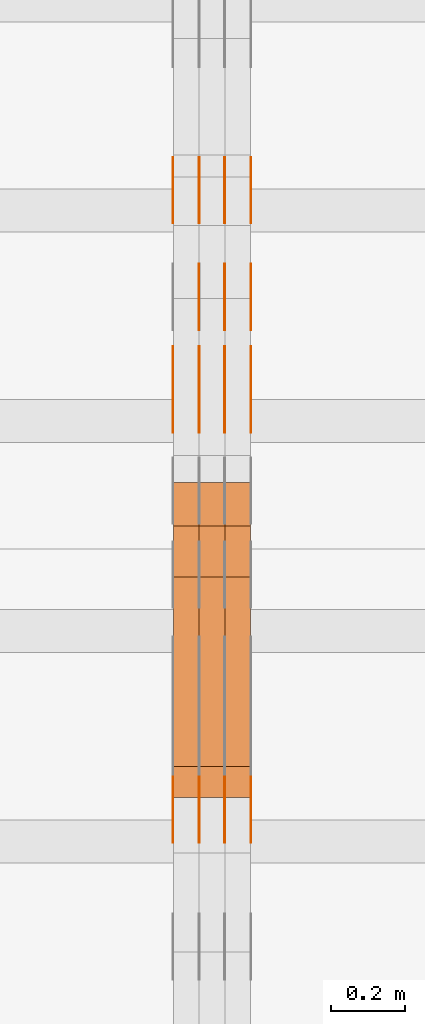
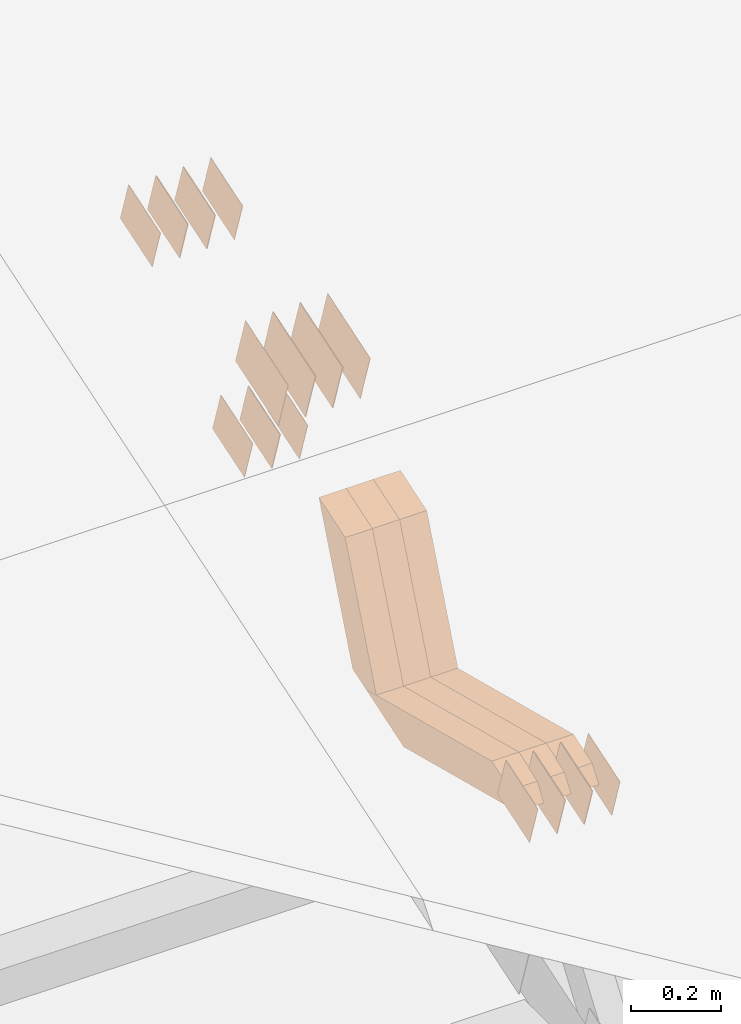
# One storey, part 116 of 385: 28 proxies.
"""IFC2X3 building model written with IfcOpenShell, lengths in millimetres."""

from ifc_helpers import new_model, entity, si_unit, converted_unit, derived_unit, direction, frame, origin, place, context, subcontext, project, spatial, polyline, outline, extrude, source, transform, mapped, material, type_object, type_shapes, element, save


model = new_model("IFC2X3")

# Units and contexts
model_context = context("Model", 3, precision=0.01, world=origin(), true_north=direction((6.12303176911189e-17, 1.0)))
body_context = subcontext(model_context, "Body", "Model", "MODEL_VIEW")
ifc_project = project(units=[si_unit("LENGTHUNIT", "METRE", prefix="MILLI"), si_unit("AREAUNIT", "SQUARE_METRE"), si_unit("VOLUMEUNIT", "CUBIC_METRE"), converted_unit("PLANEANGLEUNIT", "DEGREE", entity("IfcRatioMeasure", 0.0174532925199433), si_unit("PLANEANGLEUNIT", "RADIAN"), dimensions=[0, 0, 0, 0, 0, 0, 0]), si_unit("MASSUNIT", "GRAM", prefix="KILO"), derived_unit("MASSDENSITYUNIT", [(si_unit("MASSUNIT", "GRAM", prefix="KILO"), 1), (si_unit("LENGTHUNIT", "METRE"), -3)]), si_unit("TIMEUNIT", "SECOND"), si_unit("FREQUENCYUNIT", "HERTZ"), si_unit("THERMODYNAMICTEMPERATUREUNIT", "DEGREE_CELSIUS"), derived_unit("THERMALTRANSMITTANCEUNIT", [(si_unit("MASSUNIT", "GRAM", prefix="KILO"), 1), (si_unit("THERMODYNAMICTEMPERATUREUNIT", "KELVIN"), -1), (si_unit("TIMEUNIT", "SECOND"), -3)]), derived_unit("VOLUMETRICFLOWRATEUNIT", [(si_unit("LENGTHUNIT", "METRE"), 3), (si_unit("TIMEUNIT", "SECOND"), -1)]), si_unit("ELECTRICCURRENTUNIT", "AMPERE"), si_unit("ELECTRICVOLTAGEUNIT", "VOLT"), si_unit("POWERUNIT", "WATT"), si_unit("FORCEUNIT", "NEWTON", prefix="KILO"), si_unit("ILLUMINANCEUNIT", "LUX"), si_unit("LUMINOUSFLUXUNIT", "LUMEN"), si_unit("LUMINOUSINTENSITYUNIT", "CANDELA"), derived_unit("USERDEFINED", [(si_unit("MASSUNIT", "GRAM", prefix="KILO"), -1), (si_unit("LENGTHUNIT", "METRE"), -2), (si_unit("TIMEUNIT", "SECOND"), 3), (si_unit("LUMINOUSFLUXUNIT", "LUMEN"), 1)]), derived_unit("LINEARVELOCITYUNIT", [(si_unit("LENGTHUNIT", "METRE"), 1), (si_unit("TIMEUNIT", "SECOND"), -1)]), si_unit("PRESSUREUNIT", "PASCAL"), derived_unit("USERDEFINED", [(si_unit("LENGTHUNIT", "METRE"), -2), (si_unit("MASSUNIT", "GRAM", prefix="KILO"), 1), (si_unit("TIMEUNIT", "SECOND"), -2)])], contexts=[model_context])

# Site, building, storey
site_placement = place(None, origin())
site = spatial("IfcSite", under=ifc_project, at=site_placement, CompositionType="ELEMENT")
building_placement = place(site_placement, origin())
building = spatial("IfcBuilding", under=site, at=building_placement, CompositionType="ELEMENT")
storey_placement = place(building_placement, origin())
storey = spatial("IfcBuildingStorey", under=building, at=storey_placement, Name="Default", CompositionType="ELEMENT", Elevation=0.0)

# Proxies
ifc_material_1 = material(Name="IfcSurfaceStyle #245966")
building_element_proxy_type_1 = type_object("IfcBuildingElementProxyType", PredefinedType="NOTDEFINED", material=ifc_material_1)
shared_shape_1 = source(origin(), body_context, "Body", "SweptSolid", [
    extrude(outline(polyline([(-99.999644645517, -72.0000317581407), (100.000028485991, -72.0000317581407), (99.999644645517, 72.0000317581407), (-100.000028485991, 72.0000317581407), (-99.999644645517, -72.0000317581407)])), frame((100.000028485991, 72.0000317581407, 0.0), z_axis=(0.0, 0.0, 1.0), x_axis=(-1.0, 0.0, 0.0)), (0.0, 0.0, 1.0), 1.3),
])
type_shapes(building_element_proxy_type_1, [shared_shape_1])
proxy_1_placement = place(building_placement, frame((18386.3, 9012.6304394324, 2546.30522609783), z_axis=(-1.0, 0.0, 0.0), x_axis=(0.0, 0.951056516295154, 0.309016994374948)))
element("IfcBuildingElementProxy", 1, at=proxy_1_placement, inside=storey, type_object=building_element_proxy_type_1, material=ifc_material_1, context=body_context, shape_type="MappedRepresentation", body=[
    mapped(shared_shape_1, transform((0.0, 0.0, 0.0), scale=1.0)),
])
ifc_material_2 = material(Name="IfcSurfaceStyle #245909")
building_element_proxy_type_2 = type_object("IfcBuildingElementProxyType", PredefinedType="NOTDEFINED", material=ifc_material_2)
shared_shape_2 = source(origin(), body_context, "Body", "SweptSolid", [
    extrude(outline(polyline([(-99.999644645517, -72.0000317581407), (100.000028485991, -72.0000317581407), (99.999644645517, 72.0000317581407), (-100.000028485991, 72.0000317581407), (-99.999644645517, -72.0000317581407)])), frame((100.000028485991, 72.0000317581407, 0.0), z_axis=(0.0, 0.0, 1.0), x_axis=(-1.0, 0.0, 0.0)), (0.0, 0.0, 1.0), 1.3),
])
type_shapes(building_element_proxy_type_2, [shared_shape_2])
proxy_2_placement = place(building_placement, frame((18315.0, 9012.6304394324, 2546.30522609783), z_axis=(-1.0, 0.0, 0.0), x_axis=(0.0, 0.951056516295154, 0.309016994374948)))
element("IfcBuildingElementProxy", 2, at=proxy_2_placement, inside=storey, type_object=building_element_proxy_type_2, material=ifc_material_2, context=body_context, shape_type="MappedRepresentation", body=[
    mapped(shared_shape_2, transform((0.0, 0.0, 0.0), scale=1.0)),
])
ifc_material_3 = material(Name="IfcSurfaceStyle #245852")
building_element_proxy_type_3 = type_object("IfcBuildingElementProxyType", PredefinedType="NOTDEFINED", material=ifc_material_3)
shared_shape_3 = source(origin(), body_context, "Body", "SweptSolid", [
    extrude(outline(polyline([(-99.999644645517, -72.0000317581407), (100.000028485991, -72.0000317581407), (99.999644645517, 72.0000317581407), (-100.000028485991, 72.0000317581407), (-99.999644645517, -72.0000317581407)])), frame((100.000028485991, 72.0000317581407, 0.0), z_axis=(0.0, 0.0, 1.0), x_axis=(-1.0, 0.0, 0.0)), (0.0, 0.0, 1.0), 1.3),
])
type_shapes(building_element_proxy_type_3, [shared_shape_3])
proxy_3_placement = place(building_placement, frame((18316.3, 9012.6304394324, 2546.30522609783), z_axis=(-1.0, 0.0, 0.0), x_axis=(0.0, 0.951056516295154, 0.309016994374948)))
element("IfcBuildingElementProxy", 3, at=proxy_3_placement, inside=storey, type_object=building_element_proxy_type_3, material=ifc_material_3, context=body_context, shape_type="MappedRepresentation", body=[
    mapped(shared_shape_3, transform((0.0, 0.0, 0.0), scale=1.0)),
])
ifc_material_4 = material(Name="IfcSurfaceStyle #245795")
building_element_proxy_type_4 = type_object("IfcBuildingElementProxyType", PredefinedType="NOTDEFINED", material=ifc_material_4)
shared_shape_4 = source(origin(), body_context, "Body", "SweptSolid", [
    extrude(outline(polyline([(-99.999644645517, -72.0000317581407), (100.000028485991, -72.0000317581407), (99.999644645517, 72.0000317581407), (-100.000028485991, 72.0000317581407), (-99.999644645517, -72.0000317581407)])), frame((100.000028485991, 72.0000317581407, 0.0), z_axis=(0.0, 0.0, 1.0), x_axis=(-1.0, 0.0, 0.0)), (0.0, 0.0, 1.0), 1.29999999999998),
])
type_shapes(building_element_proxy_type_4, [shared_shape_4])
proxy_4_placement = place(building_placement, frame((18245.0, 9012.6304394324, 2546.30522609783), z_axis=(-1.0, 0.0, 0.0), x_axis=(0.0, 0.951056516295154, 0.309016994374948)))
element("IfcBuildingElementProxy", 4, at=proxy_4_placement, inside=storey, type_object=building_element_proxy_type_4, material=ifc_material_4, context=body_context, shape_type="MappedRepresentation", body=[
    mapped(shared_shape_4, transform((0.0, 0.0, 0.0), scale=1.0)),
])
ifc_material_5 = material(Name="IfcSurfaceStyle #245738")
building_element_proxy_type_5 = type_object("IfcBuildingElementProxyType", PredefinedType="NOTDEFINED", material=ifc_material_5)
shared_shape_5 = source(origin(), body_context, "Body", "SweptSolid", [
    extrude(outline(polyline([(-99.999644645517, -72.0000317581407), (100.000028485991, -72.0000317581407), (99.999644645517, 72.0000317581407), (-100.000028485991, 72.0000317581407), (-99.999644645517, -72.0000317581407)])), frame((100.000028485991, 72.0000317581407, 0.0), z_axis=(0.0, 0.0, 1.0), x_axis=(-1.0, 0.0, 0.0)), (0.0, 0.0, 1.0), 1.29999999999998),
])
type_shapes(building_element_proxy_type_5, [shared_shape_5])
proxy_5_placement = place(building_placement, frame((18246.3, 9012.6304394324, 2546.30522609783), z_axis=(-1.0, 0.0, 0.0), x_axis=(0.0, 0.951056516295154, 0.309016994374948)))
element("IfcBuildingElementProxy", 5, at=proxy_5_placement, inside=storey, type_object=building_element_proxy_type_5, material=ifc_material_5, context=body_context, shape_type="MappedRepresentation", body=[
    mapped(shared_shape_5, transform((0.0, 0.0, 0.0), scale=1.0)),
])
ifc_material_6 = material(Name="IfcSurfaceStyle #245681")
building_element_proxy_type_6 = type_object("IfcBuildingElementProxyType", PredefinedType="NOTDEFINED", material=ifc_material_6)
shared_shape_6 = source(origin(), body_context, "Body", "SweptSolid", [
    extrude(outline(polyline([(-99.999644645517, -72.0000317581407), (100.000028485991, -72.0000317581407), (99.999644645517, 72.0000317581407), (-100.000028485991, 72.0000317581407), (-99.999644645517, -72.0000317581407)])), frame((100.000028485991, 72.0000317581407, 0.0), z_axis=(0.0, 0.0, 1.0), x_axis=(-1.0, 0.0, 0.0)), (0.0, 0.0, 1.0), 1.29999999999999),
])
type_shapes(building_element_proxy_type_6, [shared_shape_6])
proxy_6_placement = place(building_placement, frame((18175.0, 9012.6304394324, 2546.30522609783), z_axis=(-1.0, 0.0, 0.0), x_axis=(0.0, 0.951056516295154, 0.309016994374948)))
element("IfcBuildingElementProxy", 6, at=proxy_6_placement, inside=storey, type_object=building_element_proxy_type_6, material=ifc_material_6, context=body_context, shape_type="MappedRepresentation", body=[
    mapped(shared_shape_6, transform((0.0, 0.0, 0.0), scale=1.0)),
])
ifc_material_7 = material(Name="IfcSurfaceStyle #245624")
building_element_proxy_type_7 = type_object("IfcBuildingElementProxyType", PredefinedType="NOTDEFINED", material=ifc_material_7)
shared_shape_7 = source(origin(), body_context, "Body", "SweptSolid", [
    extrude(outline(polyline([(-74.9998754286207, -60.0000016373506), (74.9998605591063, -60.0000016373506), (74.9998754286244, 60.0000016373506), (-74.9998605591099, 60.0000016373506), (-74.9998754286207, -60.0000016373506)])), frame((74.9998754286244, 60.0000016373506, 0.0), z_axis=(0.0, 0.0, 1.0), x_axis=(-1.0, 0.0, 0.0)), (0.0, 0.0, 1.0), 1.3),
])
type_shapes(building_element_proxy_type_7, [shared_shape_7])
proxy_7_placement = place(building_placement, frame((18386.3, 9580.89841427132, 2615.81135078741), z_axis=(-1.0, 0.0, 0.0), x_axis=(0.0, 0.951056516295154, 0.309016994374948)))
element("IfcBuildingElementProxy", 7, at=proxy_7_placement, inside=storey, type_object=building_element_proxy_type_7, material=ifc_material_7, context=body_context, shape_type="MappedRepresentation", body=[
    mapped(shared_shape_7, transform((0.0, 0.0, 0.0), scale=1.0)),
])
ifc_material_8 = material(Name="IfcSurfaceStyle #245567")
building_element_proxy_type_8 = type_object("IfcBuildingElementProxyType", PredefinedType="NOTDEFINED", material=ifc_material_8)
shared_shape_8 = source(origin(), body_context, "Body", "SweptSolid", [
    extrude(outline(polyline([(-74.9998754286207, -60.0000016373506), (74.9998605591063, -60.0000016373506), (74.9998754286244, 60.0000016373506), (-74.9998605591099, 60.0000016373506), (-74.9998754286207, -60.0000016373506)])), frame((74.9998754286244, 60.0000016373506, 0.0), z_axis=(0.0, 0.0, 1.0), x_axis=(-1.0, 0.0, 0.0)), (0.0, 0.0, 1.0), 1.3),
])
type_shapes(building_element_proxy_type_8, [shared_shape_8])
proxy_8_placement = place(building_placement, frame((18315.0, 9580.89841427132, 2615.81135078741), z_axis=(-1.0, 0.0, 0.0), x_axis=(0.0, 0.951056516295154, 0.309016994374948)))
element("IfcBuildingElementProxy", 8, at=proxy_8_placement, inside=storey, type_object=building_element_proxy_type_8, material=ifc_material_8, context=body_context, shape_type="MappedRepresentation", body=[
    mapped(shared_shape_8, transform((0.0, 0.0, 0.0), scale=1.0)),
])
ifc_material_9 = material(Name="IfcSurfaceStyle #245510")
building_element_proxy_type_9 = type_object("IfcBuildingElementProxyType", PredefinedType="NOTDEFINED", material=ifc_material_9)
shared_shape_9 = source(origin(), body_context, "Body", "SweptSolid", [
    extrude(outline(polyline([(-74.9998754286207, -60.0000016373506), (74.9998605591063, -60.0000016373506), (74.9998754286244, 60.0000016373506), (-74.9998605591099, 60.0000016373506), (-74.9998754286207, -60.0000016373506)])), frame((74.9998754286244, 60.0000016373506, 0.0), z_axis=(0.0, 0.0, 1.0), x_axis=(-1.0, 0.0, 0.0)), (0.0, 0.0, 1.0), 1.3),
])
type_shapes(building_element_proxy_type_9, [shared_shape_9])
proxy_9_placement = place(building_placement, frame((18316.3, 9580.89841427132, 2615.81135078741), z_axis=(-1.0, 0.0, 0.0), x_axis=(0.0, 0.951056516295154, 0.309016994374948)))
element("IfcBuildingElementProxy", 9, at=proxy_9_placement, inside=storey, type_object=building_element_proxy_type_9, material=ifc_material_9, context=body_context, shape_type="MappedRepresentation", body=[
    mapped(shared_shape_9, transform((0.0, 0.0, 0.0), scale=1.0)),
])
ifc_material_10 = material(Name="IfcSurfaceStyle #245453")
building_element_proxy_type_10 = type_object("IfcBuildingElementProxyType", PredefinedType="NOTDEFINED", material=ifc_material_10)
shared_shape_10 = source(origin(), body_context, "Body", "SweptSolid", [
    extrude(outline(polyline([(-74.9998754286207, -60.0000016373506), (74.9998605591063, -60.0000016373506), (74.9998754286244, 60.0000016373506), (-74.9998605591099, 60.0000016373506), (-74.9998754286207, -60.0000016373506)])), frame((74.9998754286244, 60.0000016373506, 0.0), z_axis=(0.0, 0.0, 1.0), x_axis=(-1.0, 0.0, 0.0)), (0.0, 0.0, 1.0), 1.29999999999999),
])
type_shapes(building_element_proxy_type_10, [shared_shape_10])
proxy_10_placement = place(building_placement, frame((18245.0, 9580.89841427132, 2615.81135078741), z_axis=(-1.0, 0.0, 0.0), x_axis=(0.0, 0.951056516295154, 0.309016994374948)))
element("IfcBuildingElementProxy", 10, at=proxy_10_placement, inside=storey, type_object=building_element_proxy_type_10, material=ifc_material_10, context=body_context, shape_type="MappedRepresentation", body=[
    mapped(shared_shape_10, transform((0.0, 0.0, 0.0), scale=1.0)),
])
ifc_material_11 = material(Name="IfcSurfaceStyle #245396")
building_element_proxy_type_11 = type_object("IfcBuildingElementProxyType", PredefinedType="NOTDEFINED", material=ifc_material_11)
shared_shape_11 = source(origin(), body_context, "Body", "SweptSolid", [
    extrude(outline(polyline([(-74.9998754286207, -60.0000016373506), (74.9998605591063, -60.0000016373506), (74.9998754286244, 60.0000016373506), (-74.9998605591099, 60.0000016373506), (-74.9998754286207, -60.0000016373506)])), frame((74.9998754286244, 60.0000016373506, 0.0), z_axis=(0.0, 0.0, 1.0), x_axis=(-1.0, 0.0, 0.0)), (0.0, 0.0, 1.0), 1.29999999999999),
])
type_shapes(building_element_proxy_type_11, [shared_shape_11])
proxy_11_placement = place(building_placement, frame((18246.3, 9580.89841427132, 2615.81135078741), z_axis=(-1.0, 0.0, 0.0), x_axis=(0.0, 0.951056516295154, 0.309016994374948)))
element("IfcBuildingElementProxy", 11, at=proxy_11_placement, inside=storey, type_object=building_element_proxy_type_11, material=ifc_material_11, context=body_context, shape_type="MappedRepresentation", body=[
    mapped(shared_shape_11, transform((0.0, 0.0, 0.0), scale=1.0)),
])
ifc_material_12 = material(Name="IfcSurfaceStyle #245339")
building_element_proxy_type_12 = type_object("IfcBuildingElementProxyType", PredefinedType="NOTDEFINED", material=ifc_material_12)
shared_shape_12 = source(origin(), body_context, "Body", "SweptSolid", [
    extrude(outline(polyline([(-74.9998754286207, -60.0000016373506), (74.9998605591063, -60.0000016373506), (74.9998754286244, 60.0000016373506), (-74.9998605591099, 60.0000016373506), (-74.9998754286207, -60.0000016373506)])), frame((74.9998754286244, 60.0000016373506, 0.0), z_axis=(0.0, 0.0, 1.0), x_axis=(-1.0, 0.0, 0.0)), (0.0, 0.0, 1.0), 1.29999999999999),
])
type_shapes(building_element_proxy_type_12, [shared_shape_12])
proxy_12_placement = place(building_placement, frame((18175.0, 9580.89841427132, 2615.81135078741), z_axis=(-1.0, 0.0, 0.0), x_axis=(0.0, 0.951056516295154, 0.309016994374948)))
element("IfcBuildingElementProxy", 12, at=proxy_12_placement, inside=storey, type_object=building_element_proxy_type_12, material=ifc_material_12, context=body_context, shape_type="MappedRepresentation", body=[
    mapped(shared_shape_12, transform((0.0, 0.0, 0.0), scale=1.0)),
])
ifc_material_13 = material(Name="IfcSurfaceStyle #244598")
building_element_proxy_type_13 = type_object("IfcBuildingElementProxyType", PredefinedType="NOTDEFINED", material=ifc_material_13)
shared_shape_13 = source(origin(), body_context, "Body", "SweptSolid", [
    extrude(outline(polyline([(-75.0008041947458, -59.9996998629349), (75.0007893252423, -59.9996998629349), (75.0008041947458, 59.9996998629349), (-75.0007893252423, 59.9996998629349), (-75.0008041947458, -59.9996998629349)])), frame((75.0008041947458, 60.0002282421692, 0.0), z_axis=(0.0, 0.0, 1.0), x_axis=(-1.0, 0.0, 0.0)), (0.0, 0.0, 1.0), 1.3),
])
type_shapes(building_element_proxy_type_13, [shared_shape_13])
proxy_13_placement = place(building_placement, frame((18386.3, 9291.048828125, 2194.94482421875), z_axis=(-1.0, 0.0, 0.0), x_axis=(0.0, 0.951056516295124, 0.309016994375039)))
element("IfcBuildingElementProxy", 13, at=proxy_13_placement, inside=storey, type_object=building_element_proxy_type_13, material=ifc_material_13, context=body_context, shape_type="MappedRepresentation", body=[
    mapped(shared_shape_13, transform((0.0, 0.0, 0.0), scale=1.0)),
])
ifc_material_14 = material(Name="IfcSurfaceStyle #244541")
building_element_proxy_type_14 = type_object("IfcBuildingElementProxyType", PredefinedType="NOTDEFINED", material=ifc_material_14)
shared_shape_14 = source(origin(), body_context, "Body", "SweptSolid", [
    extrude(outline(polyline([(-75.0008041947458, -59.9996998629349), (75.0007893252423, -59.9996998629349), (75.0008041947458, 59.9996998629349), (-75.0007893252423, 59.9996998629349), (-75.0008041947458, -59.9996998629349)])), frame((75.0008041947458, 60.0002282421692, 0.0), z_axis=(0.0, 0.0, 1.0), x_axis=(-1.0, 0.0, 0.0)), (0.0, 0.0, 1.0), 1.3),
])
type_shapes(building_element_proxy_type_14, [shared_shape_14])
proxy_14_placement = place(building_placement, frame((18315.0, 9291.048828125, 2194.94482421875), z_axis=(-1.0, 0.0, 0.0), x_axis=(0.0, 0.951056516295124, 0.309016994375039)))
element("IfcBuildingElementProxy", 14, at=proxy_14_placement, inside=storey, type_object=building_element_proxy_type_14, material=ifc_material_14, context=body_context, shape_type="MappedRepresentation", body=[
    mapped(shared_shape_14, transform((0.0, 0.0, 0.0), scale=1.0)),
])
ifc_material_15 = material(Name="IfcSurfaceStyle #244484")
building_element_proxy_type_15 = type_object("IfcBuildingElementProxyType", PredefinedType="NOTDEFINED", material=ifc_material_15)
shared_shape_15 = source(origin(), body_context, "Body", "SweptSolid", [
    extrude(outline(polyline([(-75.0008041947458, -59.9996998629349), (75.0007893252423, -59.9996998629349), (75.0008041947458, 59.9996998629349), (-75.0007893252423, 59.9996998629349), (-75.0008041947458, -59.9996998629349)])), frame((75.0008041947458, 60.0002282421692, 0.0), z_axis=(0.0, 0.0, 1.0), x_axis=(-1.0, 0.0, 0.0)), (0.0, 0.0, 1.0), 1.3),
])
type_shapes(building_element_proxy_type_15, [shared_shape_15])
proxy_15_placement = place(building_placement, frame((18316.3, 9291.048828125, 2194.94482421875), z_axis=(-1.0, 0.0, 0.0), x_axis=(0.0, 0.951056516295124, 0.309016994375039)))
element("IfcBuildingElementProxy", 15, at=proxy_15_placement, inside=storey, type_object=building_element_proxy_type_15, material=ifc_material_15, context=body_context, shape_type="MappedRepresentation", body=[
    mapped(shared_shape_15, transform((0.0, 0.0, 0.0), scale=1.0)),
])
ifc_material_16 = material(Name="IfcSurfaceStyle #244427")
building_element_proxy_type_16 = type_object("IfcBuildingElementProxyType", PredefinedType="NOTDEFINED", material=ifc_material_16)
shared_shape_16 = source(origin(), body_context, "Body", "SweptSolid", [
    extrude(outline(polyline([(-75.0008041947458, -59.9996998629349), (75.0007893252423, -59.9996998629349), (75.0008041947458, 59.9996998629349), (-75.0007893252423, 59.9996998629349), (-75.0008041947458, -59.9996998629349)])), frame((75.0008041947458, 60.0002282421692, 0.0), z_axis=(0.0, 0.0, 1.0), x_axis=(-1.0, 0.0, 0.0)), (0.0, 0.0, 1.0), 1.29999999999999),
])
type_shapes(building_element_proxy_type_16, [shared_shape_16])
proxy_16_placement = place(building_placement, frame((18245.0, 9291.048828125, 2194.94482421875), z_axis=(-1.0, 0.0, 0.0), x_axis=(0.0, 0.951056516295124, 0.309016994375039)))
element("IfcBuildingElementProxy", 16, at=proxy_16_placement, inside=storey, type_object=building_element_proxy_type_16, material=ifc_material_16, context=body_context, shape_type="MappedRepresentation", body=[
    mapped(shared_shape_16, transform((0.0, 0.0, 0.0), scale=1.0)),
])
ifc_material_17 = material(Name="IfcSurfaceStyle #232628")
building_element_proxy_type_17 = type_object("IfcBuildingElementProxyType", PredefinedType="NOTDEFINED", material=ifc_material_17)
shared_shape_17 = source(origin(), body_context, "Body", "SweptSolid", [
    extrude(outline(polyline([(-74.9998754286253, -60.0000016373506), (74.9998605591091, -60.0000016373506), (74.9998754286234, 60.0000016373506), (-74.9998605591072, 60.0000016373506), (-74.9998754286253, -60.0000016373506)])), frame((75.0007355357002, 60.0002637031812, 0.0), z_axis=(0.0, 0.0, 1.0), x_axis=(-1.0, 0.0, 0.0)), (0.0, 0.0, 1.0), 1.3),
])
type_shapes(building_element_proxy_type_17, [shared_shape_17])
proxy_17_placement = place(building_placement, frame((18386.3, 7899.79204652808, 2069.58672486412), z_axis=(-1.0, 0.0, 0.0), x_axis=(0.0, 0.951056516295154, 0.309016994374948)))
element("IfcBuildingElementProxy", 17, at=proxy_17_placement, inside=storey, type_object=building_element_proxy_type_17, material=ifc_material_17, context=body_context, shape_type="MappedRepresentation", body=[
    mapped(shared_shape_17, transform((0.0, 0.0, 0.0), scale=1.0)),
])
ifc_material_18 = material(Name="IfcSurfaceStyle #232571")
building_element_proxy_type_18 = type_object("IfcBuildingElementProxyType", PredefinedType="NOTDEFINED", material=ifc_material_18)
shared_shape_18 = source(origin(), body_context, "Body", "SweptSolid", [
    extrude(outline(polyline([(-74.9998754286253, -60.0000016373506), (74.9998605591091, -60.0000016373506), (74.9998754286234, 60.0000016373506), (-74.9998605591072, 60.0000016373506), (-74.9998754286253, -60.0000016373506)])), frame((75.0007355357002, 60.0002637031812, 0.0), z_axis=(0.0, 0.0, 1.0), x_axis=(-1.0, 0.0, 0.0)), (0.0, 0.0, 1.0), 1.3),
])
type_shapes(building_element_proxy_type_18, [shared_shape_18])
proxy_18_placement = place(building_placement, frame((18315.0, 7899.79204652808, 2069.58672486412), z_axis=(-1.0, 0.0, 0.0), x_axis=(0.0, 0.951056516295154, 0.309016994374948)))
element("IfcBuildingElementProxy", 18, at=proxy_18_placement, inside=storey, type_object=building_element_proxy_type_18, material=ifc_material_18, context=body_context, shape_type="MappedRepresentation", body=[
    mapped(shared_shape_18, transform((0.0, 0.0, 0.0), scale=1.0)),
])
ifc_material_19 = material(Name="IfcSurfaceStyle #232514")
building_element_proxy_type_19 = type_object("IfcBuildingElementProxyType", PredefinedType="NOTDEFINED", material=ifc_material_19)
shared_shape_19 = source(origin(), body_context, "Body", "SweptSolid", [
    extrude(outline(polyline([(-74.9998754286253, -60.0000016373506), (74.9998605591091, -60.0000016373506), (74.9998754286234, 60.0000016373506), (-74.9998605591072, 60.0000016373506), (-74.9998754286253, -60.0000016373506)])), frame((75.0007355357002, 60.0002637031812, 0.0), z_axis=(0.0, 0.0, 1.0), x_axis=(-1.0, 0.0, 0.0)), (0.0, 0.0, 1.0), 1.3),
])
type_shapes(building_element_proxy_type_19, [shared_shape_19])
proxy_19_placement = place(building_placement, frame((18316.3, 7899.79204652808, 2069.58672486412), z_axis=(-1.0, 0.0, 0.0), x_axis=(0.0, 0.951056516295154, 0.309016994374948)))
element("IfcBuildingElementProxy", 19, at=proxy_19_placement, inside=storey, type_object=building_element_proxy_type_19, material=ifc_material_19, context=body_context, shape_type="MappedRepresentation", body=[
    mapped(shared_shape_19, transform((0.0, 0.0, 0.0), scale=1.0)),
])
ifc_material_20 = material(Name="IfcSurfaceStyle #232457")
building_element_proxy_type_20 = type_object("IfcBuildingElementProxyType", PredefinedType="NOTDEFINED", material=ifc_material_20)
shared_shape_20 = source(origin(), body_context, "Body", "SweptSolid", [
    extrude(outline(polyline([(-74.9998754286253, -60.0000016373506), (74.9998605591091, -60.0000016373506), (74.9998754286234, 60.0000016373506), (-74.9998605591072, 60.0000016373506), (-74.9998754286253, -60.0000016373506)])), frame((75.0007355357002, 60.0002637031812, 0.0), z_axis=(0.0, 0.0, 1.0), x_axis=(-1.0, 0.0, 0.0)), (0.0, 0.0, 1.0), 1.29999999999999),
])
type_shapes(building_element_proxy_type_20, [shared_shape_20])
proxy_20_placement = place(building_placement, frame((18245.0, 7899.79204652808, 2069.58672486412), z_axis=(-1.0, 0.0, 0.0), x_axis=(0.0, 0.951056516295154, 0.309016994374948)))
element("IfcBuildingElementProxy", 20, at=proxy_20_placement, inside=storey, type_object=building_element_proxy_type_20, material=ifc_material_20, context=body_context, shape_type="MappedRepresentation", body=[
    mapped(shared_shape_20, transform((0.0, 0.0, 0.0), scale=1.0)),
])
ifc_material_21 = material(Name="IfcSurfaceStyle #232400")
building_element_proxy_type_21 = type_object("IfcBuildingElementProxyType", PredefinedType="NOTDEFINED", material=ifc_material_21)
shared_shape_21 = source(origin(), body_context, "Body", "SweptSolid", [
    extrude(outline(polyline([(-74.9998754286253, -60.0000016373506), (74.9998605591091, -60.0000016373506), (74.9998754286234, 60.0000016373506), (-74.9998605591072, 60.0000016373506), (-74.9998754286253, -60.0000016373506)])), frame((75.0007355357002, 60.0002637031812, 0.0), z_axis=(0.0, 0.0, 1.0), x_axis=(-1.0, 0.0, 0.0)), (0.0, 0.0, 1.0), 1.29999999999999),
])
type_shapes(building_element_proxy_type_21, [shared_shape_21])
proxy_21_placement = place(building_placement, frame((18246.3, 7899.79204652808, 2069.58672486412), z_axis=(-1.0, 0.0, 0.0), x_axis=(0.0, 0.951056516295154, 0.309016994374948)))
element("IfcBuildingElementProxy", 21, at=proxy_21_placement, inside=storey, type_object=building_element_proxy_type_21, material=ifc_material_21, context=body_context, shape_type="MappedRepresentation", body=[
    mapped(shared_shape_21, transform((0.0, 0.0, 0.0), scale=1.0)),
])
ifc_material_22 = material(Name="IfcSurfaceStyle #232343")
building_element_proxy_type_22 = type_object("IfcBuildingElementProxyType", PredefinedType="NOTDEFINED", material=ifc_material_22)
shared_shape_22 = source(origin(), body_context, "Body", "SweptSolid", [
    extrude(outline(polyline([(-74.9998754286253, -60.0000016373506), (74.9998605591091, -60.0000016373506), (74.9998754286234, 60.0000016373506), (-74.9998605591072, 60.0000016373506), (-74.9998754286253, -60.0000016373506)])), frame((75.0007355357002, 60.0002637031812, 0.0), z_axis=(0.0, 0.0, 1.0), x_axis=(-1.0, 0.0, 0.0)), (0.0, 0.0, 1.0), 1.29999999999999),
])
type_shapes(building_element_proxy_type_22, [shared_shape_22])
proxy_22_placement = place(building_placement, frame((18175.0, 7899.79204652808, 2069.58672486412), z_axis=(-1.0, 0.0, 0.0), x_axis=(0.0, 0.951056516295154, 0.309016994374948)))
element("IfcBuildingElementProxy", 22, at=proxy_22_placement, inside=storey, type_object=building_element_proxy_type_22, material=ifc_material_22, context=body_context, shape_type="MappedRepresentation", body=[
    mapped(shared_shape_22, transform((0.0, 0.0, 0.0), scale=1.0)),
])
ifc_material_23 = material(Name="IfcSurfaceStyle #220244")
building_element_proxy_type_23 = type_object("IfcBuildingElementProxyType", Name="T1-W45 220242", PredefinedType="NOTDEFINED", material=ifc_material_23)
shared_shape_23 = source(origin(), body_context, "Body", "SweptSolid", [
    extrude(outline(polyline([(-275.953018340717, -47.500197738425), (128.971267956636, -47.5001977384251), (168.669977842085, -0.000132525443043008), (174.867371111815, 47.5002640011466), (-196.55559856982, 47.5002640011466), (-275.953018340717, -47.500197738425)])), frame((174.867371111815, 47.5002640011466, 0.0), z_axis=(0.0, 0.0, 1.0), x_axis=(-1.0, 0.0, 0.0)), (0.0, 0.0, 1.0), 70.0),
])
type_shapes(building_element_proxy_type_23, [shared_shape_23])
proxy_23_placement = place(building_placement, frame((18385.0, 8621.494140625, 1941.33422851563), z_axis=(-1.0, 0.0, 0.0), x_axis=(0.0, 0.372787901688292, 0.927916580493549)))
element("IfcBuildingElementProxy", 23, at=proxy_23_placement, inside=storey, type_object=building_element_proxy_type_23, material=ifc_material_23, Name="T1-W45", context=body_context, shape_type="MappedRepresentation", body=[
    mapped(shared_shape_23, transform((0.0, 0.0, 0.0), scale=1.0)),
])
ifc_material_24 = material(Name="IfcSurfaceStyle #220178")
building_element_proxy_type_24 = type_object("IfcBuildingElementProxyType", Name="T1-W45 220176", PredefinedType="NOTDEFINED", material=ifc_material_24)
shared_shape_24 = source(origin(), body_context, "Body", "SweptSolid", [
    extrude(outline(polyline([(-275.953018340717, -47.500197738425), (128.971267956636, -47.5001977384251), (168.669977842085, -0.000132525443043008), (174.867371111815, 47.5002640011466), (-196.55559856982, 47.5002640011466), (-275.953018340717, -47.500197738425)])), frame((174.867371111815, 47.5002640011466, 0.0), z_axis=(0.0, 0.0, 1.0), x_axis=(-1.0, 0.0, 0.0)), (0.0, 0.0, 1.0), 70.0),
])
type_shapes(building_element_proxy_type_24, [shared_shape_24])
proxy_24_placement = place(building_placement, frame((18315.0, 8621.494140625, 1941.33422851563), z_axis=(-1.0, 0.0, 0.0), x_axis=(0.0, 0.372787901688292, 0.927916580493549)))
element("IfcBuildingElementProxy", 24, at=proxy_24_placement, inside=storey, type_object=building_element_proxy_type_24, material=ifc_material_24, Name="T1-W45", context=body_context, shape_type="MappedRepresentation", body=[
    mapped(shared_shape_24, transform((0.0, 0.0, 0.0), scale=1.0)),
])
ifc_material_25 = material(Name="IfcSurfaceStyle #220112")
building_element_proxy_type_25 = type_object("IfcBuildingElementProxyType", Name="T1-W45 220110", PredefinedType="NOTDEFINED", material=ifc_material_25)
shared_shape_25 = source(origin(), body_context, "Body", "SweptSolid", [
    extrude(outline(polyline([(-275.953018340717, -47.500197738425), (128.971267956636, -47.5001977384251), (168.669977842085, -0.000132525443043008), (174.867371111815, 47.5002640011466), (-196.55559856982, 47.5002640011466), (-275.953018340717, -47.500197738425)])), frame((174.867371111815, 47.5002640011466, 0.0), z_axis=(0.0, 0.0, 1.0), x_axis=(-1.0, 0.0, 0.0)), (0.0, 0.0, 1.0), 70.0),
])
type_shapes(building_element_proxy_type_25, [shared_shape_25])
proxy_25_placement = place(building_placement, frame((18245.0, 8621.494140625, 1941.33422851563), z_axis=(-1.0, 0.0, 0.0), x_axis=(0.0, 0.372787901688292, 0.927916580493549)))
element("IfcBuildingElementProxy", 25, at=proxy_25_placement, inside=storey, type_object=building_element_proxy_type_25, material=ifc_material_25, Name="T1-W45", context=body_context, shape_type="MappedRepresentation", body=[
    mapped(shared_shape_25, transform((0.0, 0.0, 0.0), scale=1.0)),
])
ifc_material_26 = material(Name="IfcSurfaceStyle #219848")
building_element_proxy_type_26 = type_object("IfcBuildingElementProxyType", Name="T1-W11 219846", PredefinedType="NOTDEFINED", material=ifc_material_26)
shared_shape_26 = source(origin(), body_context, "Body", "SweptSolid", [
    extrude(outline(polyline([(-261.366417792209, -47.5000378467523), (260.949520182121, -47.5000378467523), (242.928845159301, -7.41559889341215e-06), (168.237407166939, 47.5000415545517), (-410.749354716152, 47.5000415545517), (-261.366417792209, -47.5000378467523)])), frame((260.949520182121, 47.5000415545517, 0.0), z_axis=(0.0, 0.0, 1.0), x_axis=(-1.0, 0.0, 0.0)), (0.0, 0.0, 1.0), 70.0),
])
type_shapes(building_element_proxy_type_26, [shared_shape_26])
proxy_26_placement = place(building_placement, frame((18385.0, 8017.44318793234, 2097.03832883996), z_axis=(-1.0, 0.0, 0.0), x_axis=(0.0, 0.968347201599873, -0.249607085543851)))
element("IfcBuildingElementProxy", 26, at=proxy_26_placement, inside=storey, type_object=building_element_proxy_type_26, material=ifc_material_26, Name="T1-W11", context=body_context, shape_type="MappedRepresentation", body=[
    mapped(shared_shape_26, transform((0.0, 0.0, 0.0), scale=1.0)),
])
ifc_material_27 = material(Name="IfcSurfaceStyle #219782")
building_element_proxy_type_27 = type_object("IfcBuildingElementProxyType", Name="T1-W11 219780", PredefinedType="NOTDEFINED", material=ifc_material_27)
shared_shape_27 = source(origin(), body_context, "Body", "SweptSolid", [
    extrude(outline(polyline([(-261.366417792209, -47.5000378467523), (260.949520182121, -47.5000378467523), (242.928845159301, -7.41559889341215e-06), (168.237407166939, 47.5000415545517), (-410.749354716152, 47.5000415545517), (-261.366417792209, -47.5000378467523)])), frame((260.949520182121, 47.5000415545517, 0.0), z_axis=(0.0, 0.0, 1.0), x_axis=(-1.0, 0.0, 0.0)), (0.0, 0.0, 1.0), 70.0),
])
type_shapes(building_element_proxy_type_27, [shared_shape_27])
proxy_27_placement = place(building_placement, frame((18315.0, 8017.44318793234, 2097.03832883996), z_axis=(-1.0, 0.0, 0.0), x_axis=(0.0, 0.968347201599873, -0.249607085543851)))
element("IfcBuildingElementProxy", 27, at=proxy_27_placement, inside=storey, type_object=building_element_proxy_type_27, material=ifc_material_27, Name="T1-W11", context=body_context, shape_type="MappedRepresentation", body=[
    mapped(shared_shape_27, transform((0.0, 0.0, 0.0), scale=1.0)),
])
ifc_material_28 = material(Name="IfcSurfaceStyle #219716")
building_element_proxy_type_28 = type_object("IfcBuildingElementProxyType", Name="T1-W11 219714", PredefinedType="NOTDEFINED", material=ifc_material_28)
shared_shape_28 = source(origin(), body_context, "Body", "SweptSolid", [
    extrude(outline(polyline([(-261.366417792209, -47.5000378467523), (260.949520182121, -47.5000378467523), (242.928845159301, -7.41559889341215e-06), (168.237407166939, 47.5000415545517), (-410.749354716152, 47.5000415545517), (-261.366417792209, -47.5000378467523)])), frame((260.949520182121, 47.5000415545517, 0.0), z_axis=(0.0, 0.0, 1.0), x_axis=(-1.0, 0.0, 0.0)), (0.0, 0.0, 1.0), 70.0),
])
type_shapes(building_element_proxy_type_28, [shared_shape_28])
proxy_28_placement = place(building_placement, frame((18245.0, 8017.44318793234, 2097.03832883996), z_axis=(-1.0, 0.0, 0.0), x_axis=(0.0, 0.968347201599873, -0.249607085543851)))
element("IfcBuildingElementProxy", 28, at=proxy_28_placement, inside=storey, type_object=building_element_proxy_type_28, material=ifc_material_28, Name="T1-W11", context=body_context, shape_type="MappedRepresentation", body=[
    mapped(shared_shape_28, transform((0.0, 0.0, 0.0), scale=1.0)),
])

save(model, "model.ifc")
